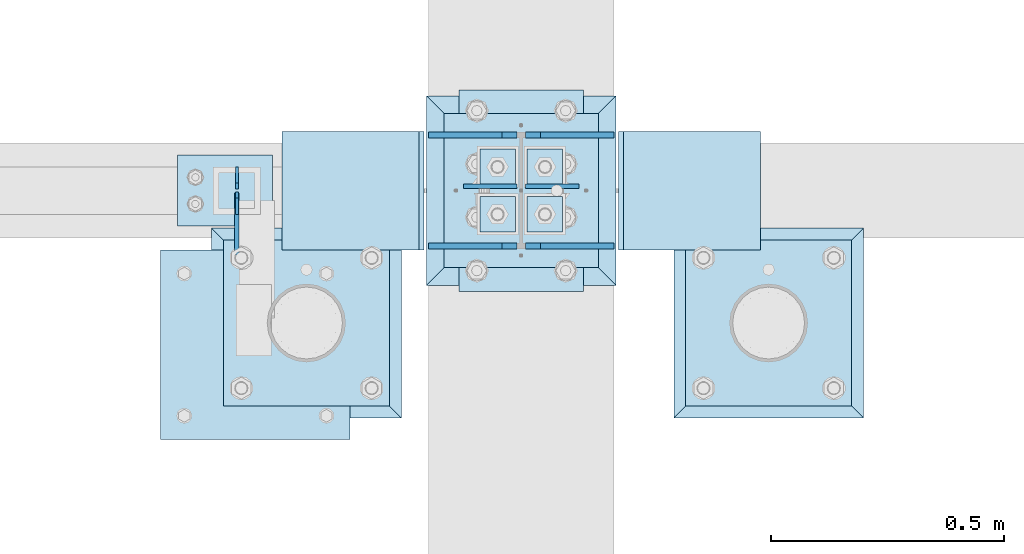
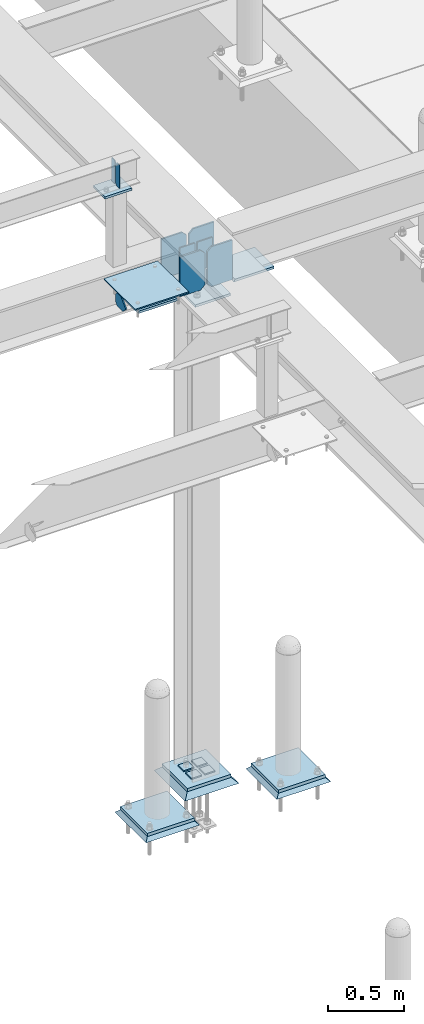
# One storey, part 3012 of 3843: 24 plates, 14 elements without a shape of their own.
"""IFC2X3 building model written with IfcOpenShell, lengths in millimetres."""

from ifc_helpers import new_model, si_unit, frame, origin_with_axes, place, context, subcontext, project, spatial, faceted_brep, material, type_object, element, aggregate, save


model = new_model("IFC2X3")

# Units and contexts
model_context = context("Model", 3, precision=1e-05, world=origin_with_axes())
body_context = subcontext(model_context, "Body", "Model", "MODEL_VIEW")
ifc_project = project(units=[si_unit("LENGTHUNIT", "METRE", prefix="MILLI"), si_unit("AREAUNIT", "SQUARE_METRE"), si_unit("VOLUMEUNIT", "CUBIC_METRE"), si_unit("MASSUNIT", "GRAM", prefix="KILO"), si_unit("TIMEUNIT", "SECOND"), si_unit("PLANEANGLEUNIT", "RADIAN"), si_unit("SOLIDANGLEUNIT", "STERADIAN"), si_unit("THERMODYNAMICTEMPERATUREUNIT", "DEGREE_CELSIUS"), si_unit("LUMINOUSINTENSITYUNIT", "LUMEN")], contexts=[model_context])

# Site, building, storey
site_placement = place(None, origin_with_axes())
site = spatial("IfcSite", under=ifc_project, at=site_placement, CompositionType="ELEMENT")
building_placement = place(site_placement, origin_with_axes())
building = spatial("IfcBuilding", under=site, at=building_placement, Name="Undefined", CompositionType="ELEMENT")
storey_placement = place(building_placement, origin_with_axes())
storey = spatial("IfcBuildingStorey", under=building, at=storey_placement, Name="Undefined", CompositionType="ELEMENT", Elevation=0.0)

# Assembly, plate
assembly_1_placement = place(storey_placement, origin_with_axes())
assembly_1 = element("IfcElementAssembly", 1, at=assembly_1_placement, inside=storey, Name="PIPE_BOLLARD", AssemblyPlace="NOTDEFINED", PredefinedType="RIGID_FRAME")
ifc_material_1 = material(Name="STEEL/A572-50")
plate_type_1 = type_object("IfcPlateType", PredefinedType="NOTDEFINED")
plate_1_placement = place(assembly_1_placement, frame((35937.8715698242, 14537.1457781578, 30518.1), z_axis=(0.0, 1.0, 0.0), x_axis=(1.0, 0.0, 0.0)))
plate_1 = element("IfcPlate", 2, at=plate_1_placement, type_object=plate_type_1, material=ifc_material_1, Name="PLATE", context=body_context, shape_type="Brep", body=[
    faceted_brep([(0.0, -12.6999999999971, 0.0), (0.0, -12.7000000000007, 355.600000000006), (0.0, 12.7000000000007, 355.600000000006), (0.0, 12.6999999999971, 0.0), (355.599999999999, -12.7000000000007, 355.600000000006), (355.599999999999, 12.7000000000007, 355.600000000006), (355.599999999999, -12.7000000000007, 0.0), (355.599999999999, 12.7000000000007, 0.0)], [[[0, 1, 2, 3]], [[1, 4, 5, 2]], [[4, 6, 7, 5]], [[6, 0, 3, 7]], [[5, 7, 3, 2]], [[6, 4, 1, 0]]]),
])
aggregate(assembly_1, [plate_1])

assembly_2_placement = place(storey_placement, origin_with_axes())
assembly_2 = element("IfcElementAssembly", 3, at=assembly_2_placement, inside=storey, Name="PIPE_BOLLARD", AssemblyPlace="NOTDEFINED", PredefinedType="RIGID_FRAME")
plate_2_placement = place(assembly_2_placement, frame((36928.4721557617, 14537.1457781578, 30518.1), z_axis=(0.0, 1.0, 0.0), x_axis=(1.0, 0.0, 0.0)))
plate_2 = element("IfcPlate", 4, at=plate_2_placement, type_object=plate_type_1, material=ifc_material_1, Name="PLATE", context=body_context, shape_type="Brep", body=[
    faceted_brep([(0.0, -12.6999999999971, 0.0), (0.0, -12.7000000000007, 355.600000000006), (0.0, 12.7000000000007, 355.600000000006), (0.0, 12.6999999999971, 0.0), (355.599999999999, -12.7000000000007, 355.600000000006), (355.599999999999, 12.7000000000007, 355.600000000006), (355.599999999999, -12.7000000000007, 0.0), (355.599999999999, 12.7000000000007, 0.0)], [[[0, 1, 2, 3]], [[1, 4, 5, 2]], [[4, 6, 7, 5]], [[6, 0, 3, 7]], [[5, 7, 3, 2]], [[6, 4, 1, 0]]]),
])
aggregate(assembly_2, [plate_2])

assembly_3_placement = place(storey_placement, origin_with_axes())
assembly_3 = element("IfcElementAssembly", 5, at=assembly_3_placement, inside=storey, Name="GROUT", AssemblyPlace="NOTDEFINED", PredefinedType="REINFORCEMENT_UNIT")
ifc_material_2 = material(Name="CONCRETE/Concrete_Undefined")
plate_type_2 = type_object("IfcPlateType", PredefinedType="NOTDEFINED")
plate_3_placement = place(assembly_3_placement, frame((35912.4715698242, 14511.7457781578, 30492.7), z_axis=(0.0, 1.0, 0.0), x_axis=(1.0, 0.0, 0.0)))
plate_3 = element("IfcPlate", 6, at=plate_3_placement, type_object=plate_type_2, material=ifc_material_2, Name="GROUT", context=body_context, shape_type="Brep", body=[
    faceted_brep([(25.4000000001906, -12.6999999998552, 380.999999999505), (0.0, 12.7000000000007, 406.399999999994), (0.0, 12.6999999999971, 0.0), (25.4000000001906, -12.6999999999898, 25.4000000004453), (380.999999999833, -12.6999999998588, 25.4000000004453), (406.400000000001, 12.7000000000007, 0.0), (406.400000000001, 12.7000000000007, 406.399999999994), (380.999999999833, -12.6999999999898, 380.999999999505)], [[[0, 1, 2, 3]], [[4, 5, 6, 7]], [[4, 7, 0, 3]], [[5, 4, 3, 2]], [[6, 5, 2, 1]], [[7, 6, 1, 0]]]),
])
aggregate(assembly_3, [plate_3])

assembly_4_placement = place(storey_placement, origin_with_axes())
assembly_4 = element("IfcElementAssembly", 7, at=assembly_4_placement, inside=storey, Name="GROUT", AssemblyPlace="NOTDEFINED", PredefinedType="REINFORCEMENT_UNIT")
plate_4_placement = place(assembly_4_placement, frame((36903.0721557617, 14511.7457781578, 30492.7), z_axis=(0.0, 1.0, 0.0), x_axis=(1.0, 0.0, 0.0)))
plate_4 = element("IfcPlate", 8, at=plate_4_placement, type_object=plate_type_2, material=ifc_material_2, Name="GROUT", context=body_context, shape_type="Brep", body=[
    faceted_brep([(25.4000000001906, -12.6999999998552, 380.999999999505), (0.0, 12.7000000000007, 406.399999999994), (0.0, 12.6999999999971, 0.0), (25.4000000001906, -12.6999999999898, 25.4000000004453), (380.999999999833, -12.6999999998588, 25.4000000004453), (406.400000000001, 12.7000000000007, 0.0), (406.400000000001, 12.7000000000007, 406.399999999994), (380.999999999833, -12.6999999999898, 380.999999999505)], [[[0, 1, 2, 3]], [[4, 5, 6, 7]], [[4, 7, 0, 3]], [[5, 4, 3, 2]], [[6, 5, 2, 1]], [[7, 6, 1, 0]]]),
])
aggregate(assembly_4, [plate_4])

# Assembly, plates
assembly_5_placement = place(storey_placement, origin_with_axes())
assembly_5 = element("IfcElementAssembly", 9, at=assembly_5_placement, inside=storey, Name="BEAM", AssemblyPlace="NOTDEFINED", PredefinedType="RIGID_FRAME")
plate_type_3 = type_object("IfcPlateType", PredefinedType="NOTDEFINED")
plate_5_placement = place(assembly_5_placement, frame((35966.4, 15049.5, 35615.5624969482), z_axis=(0.0, 0.0, -1.0), x_axis=(0.0, -1.0, 0.0)))
plate_5 = element("IfcPlate", 10, at=plate_5_placement, type_object=plate_type_3, material=ifc_material_1, Name="STIFFENER", context=body_context, shape_type="Brep", body=[
    faceted_brep([(0.0, -3.17499999999927, 0.0), (0.0, -3.17500000000291, 187.324999999997), (0.0, 3.17500000000291, 187.324999999997), (0.0, 3.17499999999927, 0.0), (34.9250001907349, -3.17500000000291, 187.324999999997), (34.9250001907349, 3.17500000000291, 187.324999999997), (47.625, -3.17500000000291, 174.625000190732), (47.625, 3.17500000000291, 174.625000190732), (47.625, -3.17499999999927, 12.6999998092651), (47.625, 3.17499999999927, 12.6999998092651), (34.9250001907349, -3.17499999999927, 0.0), (34.9250001907349, 3.17499999999927, 0.0)], [[[0, 1, 2, 3]], [[1, 4, 5, 2]], [[4, 6, 7, 5]], [[6, 8, 9, 7]], [[8, 10, 11, 9]], [[10, 0, 3, 11]], [[5, 7, 9, 11, 3, 2]], [[10, 8, 6, 4, 1, 0]]]),
])
plate_6_placement = place(assembly_5_placement, frame((35966.4, 14947.9, 35615.5624969482), z_axis=(0.0, 0.0, -1.0), x_axis=(0.0, 1.0, 0.0)))
plate_6 = element("IfcPlate", 11, at=plate_6_placement, type_object=plate_type_3, material=ifc_material_1, Name="STIFFENER", context=body_context, shape_type="Brep", body=[
    faceted_brep([(0.0, -3.17499999999927, 0.0), (0.0, -3.17500000000291, 187.324999999997), (0.0, 3.17500000000291, 187.324999999997), (0.0, 3.17499999999927, 0.0), (34.9250001907349, -3.17500000000291, 187.324999999997), (34.9250001907349, 3.17500000000291, 187.324999999997), (47.625, -3.17500000000291, 174.625000190732), (47.625, 3.17500000000291, 174.625000190732), (47.625, -3.17499999999927, 12.6999998092651), (47.625, 3.17499999999927, 12.6999998092651), (34.9250001907349, -3.17499999999927, 0.0), (34.9250001907349, 3.17499999999927, 0.0)], [[[0, 1, 2, 3]], [[1, 4, 5, 2]], [[4, 6, 7, 5]], [[6, 8, 9, 7]], [[8, 10, 11, 9]], [[10, 0, 3, 11]], [[5, 7, 9, 11, 3, 2]], [[10, 8, 6, 4, 1, 0]]]),
])
aggregate(assembly_5, [plate_5, plate_6])

assembly_6_placement = place(storey_placement, origin_with_axes())
assembly_6 = element("IfcElementAssembly", 12, at=assembly_6_placement, inside=storey, Name="BEAM", AssemblyPlace="NOTDEFINED", PredefinedType="RIGID_FRAME")
plate_type_4 = type_object("IfcPlateType", PredefinedType="NOTDEFINED")
plate_7_placement = place(assembly_6_placement, frame((36585.525, 15008.225, 34747.2), z_axis=(1.0, 0.0, 0.0), x_axis=(0.0, 0.0, -1.0)))
plate_7 = element("IfcPlate", 13, at=plate_7_placement, type_object=plate_type_4, material=ifc_material_1, Name="PLATE", context=body_context, shape_type="Brep", body=[
    faceted_brep([(0.0, -4.76249999999709, 0.0), (0.0, -4.76249999999709, 114.300003051758), (0.0, 4.76249999999709, 114.300003051758), (0.0, 4.76249999999709, 0.0), (228.600006103516, -4.76249999999709, 114.300003051758), (228.600006103516, 4.76249999999709, 114.300003051758), (228.600006103079, -4.7625000004482, 7.27595761418343e-12), (228.600006103079, 4.76249999954598, -7.27595761418343e-12)], [[[0, 1, 2, 3]], [[1, 4, 5, 2]], [[4, 6, 7, 5]], [[6, 0, 3, 7]], [[5, 7, 3, 2]], [[6, 4, 1, 0]]]),
])
plate_8_placement = place(assembly_6_placement, frame((36566.475, 15008.225, 34747.2), z_axis=(-1.0, 0.0, 0.0), x_axis=(0.0, 0.0, -1.0)))
plate_8 = element("IfcPlate", 14, at=plate_8_placement, type_object=plate_type_4, material=ifc_material_1, Name="PLATE", context=body_context, shape_type="Brep", body=[
    faceted_brep([(0.0, -4.76249999999709, 0.0), (0.0, -4.76249999999709, 114.300003051758), (0.0, 4.76249999999709, 114.300003051758), (0.0, 4.76249999999709, 0.0), (228.600006103516, -4.76249999999709, 114.300003051758), (228.600006103516, 4.76249999999709, 114.300003051758), (228.600006103079, -4.7625000004482, 7.27595761418343e-12), (228.600006103079, 4.76249999954598, -7.27595761418343e-12)], [[[0, 1, 2, 3]], [[1, 4, 5, 2]], [[4, 6, 7, 5]], [[6, 0, 3, 7]], [[5, 7, 3, 2]], [[6, 4, 1, 0]]]),
])

assembly_7_placement = place(storey_placement, origin_with_axes())
assembly_7 = element("IfcElementAssembly", 15, at=assembly_7_placement, inside=storey, Name="TEMPLATE", AssemblyPlace="NOTDEFINED", PredefinedType="RIGID_FRAME")
plate_type_5 = type_object("IfcPlateType", PredefinedType="NOTDEFINED")
plate_9_placement = place(assembly_7_placement, frame((36563.3, 14986.0, 30548.2625), z_axis=(-1.0, 0.0, 0.0), x_axis=(0.0, -1.0, 0.0)))
plate_9 = element("IfcPlate", 16, at=plate_9_placement, type_object=plate_type_5, material=ifc_material_1, Name="Washer Plate", context=body_context, shape_type="Brep", body=[
    faceted_brep([(0.0, -4.76249999999709, 0.0), (-3.49245965480804e-10, -4.76249999999709, 76.1999999999462), (-3.49245965480804e-10, 4.76249999999709, 76.1999999999462), (0.0, 4.76249999999709, 0.0), (76.1999893188477, -4.76249999999709, 76.1999969482422), (76.1999893188477, 4.76249999999709, 76.1999969482422), (76.2000000012922, -4.76250000000073, 7.27595761418343e-11), (76.2000000012922, 4.76250000000073, 7.27595761418343e-11)], [[[0, 1, 2, 3]], [[1, 4, 5, 2]], [[4, 6, 7, 5]], [[6, 0, 3, 7]], [[5, 7, 3, 2]], [[6, 4, 1, 0]]]),
])
plate_10_placement = place(assembly_7_placement, frame((36664.9, 14986.0, 30548.2625), z_axis=(-1.0, 0.0, 0.0), x_axis=(0.0, -1.0, 0.0)))
plate_10 = element("IfcPlate", 17, at=plate_10_placement, type_object=plate_type_5, material=ifc_material_1, Name="Washer Plate", context=body_context, shape_type="Brep", body=[
    faceted_brep([(0.0, -4.76249999999709, 0.0), (-3.49245965480804e-10, -4.76249999999709, 76.1999999999462), (-3.49245965480804e-10, 4.76249999999709, 76.1999999999462), (0.0, 4.76249999999709, 0.0), (76.1999893188477, -4.76249999999709, 76.1999969482422), (76.1999893188477, 4.76249999999709, 76.1999969482422), (76.2000000012922, -4.76250000000073, 7.27595761418343e-11), (76.2000000012922, 4.76250000000073, 7.27595761418343e-11)], [[[0, 1, 2, 3]], [[1, 4, 5, 2]], [[4, 6, 7, 5]], [[6, 0, 3, 7]], [[5, 7, 3, 2]], [[6, 4, 1, 0]]]),
])
plate_11_placement = place(assembly_7_placement, frame((36563.3, 15087.6, 30548.2625), z_axis=(-1.0, 0.0, 0.0), x_axis=(0.0, -1.0, 0.0)))
plate_11 = element("IfcPlate", 18, at=plate_11_placement, type_object=plate_type_5, material=ifc_material_1, Name="Washer Plate", context=body_context, shape_type="Brep", body=[
    faceted_brep([(0.0, -4.76249999999709, 0.0), (-3.49245965480804e-10, -4.76249999999709, 76.1999999999462), (-3.49245965480804e-10, 4.76249999999709, 76.1999999999462), (0.0, 4.76249999999709, 0.0), (76.1999893188477, -4.76249999999709, 76.1999969482422), (76.1999893188477, 4.76249999999709, 76.1999969482422), (76.2000000012922, -4.76250000000073, 7.27595761418343e-11), (76.2000000012922, 4.76250000000073, 7.27595761418343e-11)], [[[0, 1, 2, 3]], [[1, 4, 5, 2]], [[4, 6, 7, 5]], [[6, 0, 3, 7]], [[5, 7, 3, 2]], [[6, 4, 1, 0]]]),
])
plate_12_placement = place(assembly_7_placement, frame((36664.9, 15087.6, 30548.2625), z_axis=(-1.0, 0.0, 0.0), x_axis=(0.0, -1.0, 0.0)))
plate_12 = element("IfcPlate", 19, at=plate_12_placement, type_object=plate_type_5, material=ifc_material_1, Name="Washer Plate", context=body_context, shape_type="Brep", body=[
    faceted_brep([(0.0, -4.76249999999709, 0.0), (-3.49245965480804e-10, -4.76249999999709, 76.1999999999462), (-3.49245965480804e-10, 4.76249999999709, 76.1999999999462), (0.0, 4.76249999999709, 0.0), (76.1999893188477, -4.76249999999709, 76.1999969482422), (76.1999893188477, 4.76249999999709, 76.1999969482422), (76.2000000012922, -4.76250000000073, 7.27595761418343e-11), (76.2000000012922, 4.76250000000073, 7.27595761418343e-11)], [[[0, 1, 2, 3]], [[1, 4, 5, 2]], [[4, 6, 7, 5]], [[6, 0, 3, 7]], [[5, 7, 3, 2]], [[6, 4, 1, 0]]]),
])
aggregate(assembly_7, [plate_9, plate_10, plate_11, plate_12])

# Assembly, plate
assembly_8_placement = place(storey_placement, origin_with_axes())
assembly_8 = element("IfcElementAssembly", 20, at=assembly_8_placement, inside=storey, Name="BEAM", AssemblyPlace="NOTDEFINED", PredefinedType="RIGID_FRAME")
plate_type_6 = type_object("IfcPlateType", PredefinedType="NOTDEFINED")
plate_13_placement = place(assembly_8_placement, frame((36783.9633846577, 14871.7, 34448.75), z_axis=(1.0, 0.0, 0.0), x_axis=(0.0, 1.0, 0.0)))
plate_13 = element("IfcPlate", 21, at=plate_13_placement, type_object=plate_type_6, material=ifc_material_1, Name="PLATE", context=body_context, shape_type="Brep", body=[
    faceted_brep([(253.999999999998, 9.52500000019791, 10.9986594824586), (253.999999999998, -9.52500000000146, 0.0), (0.0, -9.52500000000146, 0.0), (0.0, 9.52500000000146, 10.9986594824586), (1.81898940354586e-12, -9.52500000000146, 304.800000000003), (253.999999999998, -9.52500000000146, 304.799999999996), (253.999999999998, 9.52500000000146, 304.799999999996), (1.81898940354586e-12, 9.52500000000146, 304.800000000003)], [[[0, 1, 2, 3]], [[4, 5, 6, 7]], [[7, 6, 0, 3]], [[4, 7, 3, 2]], [[5, 4, 2, 1]], [[6, 5, 1, 0]]]),
])
aggregate(assembly_8, [plate_13])

assembly_9_placement = place(storey_placement, origin_with_axes())
assembly_9 = element("IfcElementAssembly", 22, at=assembly_9_placement, inside=storey, Name="BEAM", AssemblyPlace="NOTDEFINED", PredefinedType="RIGID_FRAME")
plate_14_placement = place(assembly_9_placement, frame((36368.0366153423, 14871.7, 34448.75), z_axis=(-1.0, 0.0, 0.0), x_axis=(0.0, 1.0, 0.0)))
plate_14 = element("IfcPlate", 23, at=plate_14_placement, type_object=plate_type_6, material=ifc_material_1, Name="PLATE", context=body_context, shape_type="Brep", body=[
    faceted_brep([(253.999999999998, -9.52500000019791, 10.9986594824586), (0.0, -9.52500000000146, 10.9986594824586), (0.0, 9.52500000000146, 0.0), (253.999999999998, 9.52500000000146, 0.0), (1.81898940354586e-12, -9.52500000000146, 304.800000000003), (253.999999999998, -9.52500000000146, 304.799999999996), (253.999999999998, 9.52500000000146, 304.799999999996), (1.81898940354586e-12, 9.52500000000146, 304.800000000003)], [[[0, 1, 2, 3]], [[4, 5, 6, 7]], [[6, 5, 0, 3]], [[7, 6, 3, 2]], [[4, 7, 2, 1]], [[5, 4, 1, 0]]]),
])
aggregate(assembly_9, [plate_14])

assembly_10_placement = place(storey_placement, origin_with_axes())
assembly_10 = element("IfcElementAssembly", 24, at=assembly_10_placement, inside=storey, Name="PLATE", AssemblyPlace="NOTDEFINED", PredefinedType="RIGID_FRAME")
plate_type_7 = type_object("IfcPlateType", PredefinedType="NOTDEFINED")
plate_15_placement = place(assembly_10_placement, frame((35966.4, 14993.9375, 34475.7375), z_axis=(0.0, -1.0, 0.0), x_axis=(0.0, 0.0, 1.0)))
plate_15 = element("IfcPlate", 25, at=plate_15_placement, type_object=plate_type_7, material=ifc_material_1, Name="PLATE", context=body_context, shape_type="Brep", body=[
    faceted_brep([(0.0, -4.76249999999709, 19.0499992370605), (0.0, -4.76249999999709, 94.5650612206882), (0.0, 4.76249999999709, 94.5650612206882), (0.0, 4.76249999999709, 19.0499992370605), (38.5980122320107, -4.76249999999709, 133.163073452699), (38.5980122320107, 4.76249999999709, 133.163073452699), (128.400573442581, -4.76249999999709, 43.3605122421359), (128.400573442581, 4.76249999999709, 43.3605122421359), (85.0400612004451, -4.76249999999709, 0.0), (85.0400612004451, 4.76249999999709, 0.0), (19.0499992370605, -4.76249999999709, 0.0), (19.0499992370605, 4.76249999999709, 0.0)], [[[0, 1, 2, 3]], [[1, 4, 5, 2]], [[4, 6, 7, 5]], [[6, 8, 9, 7]], [[8, 10, 11, 9]], [[10, 0, 3, 11]], [[5, 7, 9, 11, 3, 2]], [[10, 8, 6, 4, 1, 0]]]),
])
aggregate(assembly_10, [plate_15])

assembly_11_placement = place(storey_placement, origin_with_axes())
assembly_11 = element("IfcElementAssembly", 26, at=assembly_11_placement, inside=storey, Name="PLATE", AssemblyPlace="NOTDEFINED", PredefinedType="RIGID_FRAME")
plate_type_8 = type_object("IfcPlateType", PredefinedType="NOTDEFINED")
plate_16_placement = place(assembly_11_placement, frame((35802.8875, 14871.7, 34805.9375), z_axis=(1.0, 0.0, 0.0), x_axis=(0.0, -1.0, 0.0)))
plate_16 = element("IfcPlate", 27, at=plate_16_placement, type_object=plate_type_8, material=ifc_material_1, Name="PLATE", context=body_context, shape_type="Brep", body=[
    faceted_brep([(0.0, -4.76249999999709, 0.0), (-7.27595761418343e-12, -4.76249999999709, 406.400000000009), (-7.27595761418343e-12, 4.76249999999709, 406.400000000009), (0.0, 4.76249999999709, 0.0), (406.399999999991, -4.76249999999709, 406.400000000009), (406.399999999991, 4.76249999999709, 406.400000000009), (406.399999999998, -4.76249999999709, 7.27595761418343e-12), (406.399999999998, 4.76249999999709, 7.27595761418343e-12)], [[[0, 1, 2, 3]], [[1, 4, 5, 2]], [[4, 6, 7, 5]], [[6, 0, 3, 7]], [[5, 7, 3, 2]], [[6, 4, 1, 0]]]),
])
aggregate(assembly_11, [plate_16])

assembly_12_placement = place(storey_placement, origin_with_axes())
assembly_12 = element("IfcElementAssembly", 28, at=assembly_12_placement, inside=storey, Name="POST", AssemblyPlace="NOTDEFINED", PredefinedType="RIGID_FRAME")
plate_type_9 = type_object("IfcPlateType", PredefinedType="NOTDEFINED")
plate_17_placement = place(assembly_12_placement, frame((36042.6, 15074.9, 35410.7749969482), z_axis=(-1.0, 0.0, 0.0), x_axis=(0.0, -1.0, 0.0)))
plate_17 = element("IfcPlate", 29, at=plate_17_placement, type_object=plate_type_9, material=ifc_material_1, Name="PLATE", context=body_context, shape_type="Brep", body=[
    faceted_brep([(0.0, -9.52500000000146, 0.0), (0.0, -9.52500000000146, 203.200000000004), (0.0, 9.52500000000146, 203.200000000004), (0.0, 9.52500000000146, 0.0), (152.400000000001, -9.52500000000146, 203.200000000004), (152.400000000001, 9.52500000000146, 203.200000000004), (152.400000000001, -9.52500000000146, 0.0), (152.400000000001, 9.52500000000146, 0.0)], [[[0, 1, 2, 3]], [[1, 4, 5, 2]], [[4, 6, 7, 5]], [[6, 0, 3, 7]], [[5, 7, 3, 2]], [[6, 4, 1, 0]]]),
])
aggregate(assembly_12, [plate_17])

# Assembly, plates
assembly_13_placement = place(storey_placement, origin_with_axes())
assembly_13 = element("IfcElementAssembly", 30, at=assembly_13_placement, inside=storey, Name="COLUMN", AssemblyPlace="NOTDEFINED", PredefinedType="RIGID_FRAME")
plate_type_10 = type_object("IfcPlateType", PredefinedType="NOTDEFINED")
plate_18_placement = place(assembly_13_placement, frame((36410.9, 15163.8, 30530.8), z_axis=(1.0, 0.0, 0.0), x_axis=(0.0, -1.0, 0.0)))
plate_18 = element("IfcPlate", 31, at=plate_18_placement, type_object=plate_type_10, material=ifc_material_1, Name="PLATE", context=body_context, shape_type="Brep", body=[
    faceted_brep([(0.0, -12.6999999999971, 0.0), (0.0, -12.6999999999825, 330.199999999997), (-1.45519152283669e-11, 12.699999999968, 330.199999999997), (0.0, 12.6999999999971, 0.0), (330.200012207031, -12.7000000000007, 330.200012207031), (330.200012207031, 12.7000000000007, 330.200012207031), (330.200012207031, -12.7000000000007, 0.0), (330.200012207031, 12.7000000000007, 0.0)], [[[0, 1, 2, 3]], [[1, 4, 5, 2]], [[4, 6, 7, 5]], [[6, 0, 3, 7]], [[5, 7, 3, 2]], [[6, 4, 1, 0]]]),
])
plate_type_11 = type_object("IfcPlateType", PredefinedType="NOTDEFINED")
plate_19_placement = place(assembly_13_placement, frame((36709.35, 14782.8, 34420.175), z_axis=(0.0, 1.0, 0.0), x_axis=(-1.0, 0.0, 0.0)))
plate_19 = element("IfcPlate", 32, at=plate_19_placement, type_object=plate_type_11, material=ifc_material_1, Name="PLATE", context=body_context, shape_type="Brep", body=[
    faceted_brep([(0.0, -9.52500000000146, 0.0), (0.0, -9.52500000000146, 431.799987792969), (0.0, 9.52500000000146, 431.799987792969), (0.0, 9.52500000000146, 0.0), (266.700012207031, -9.52500000000146, 431.799987792969), (266.700012207031, 9.52500000000146, 431.799987792969), (266.700012207031, -9.52500000000146, 0.0), (266.700012207031, 9.52500000000146, 0.0)], [[[0, 1, 2, 3]], [[1, 4, 5, 2]], [[4, 6, 7, 5]], [[6, 0, 3, 7]], [[5, 7, 3, 2]], [[6, 4, 1, 0]]]),
])
aggregate(assembly_13, [plate_19, plate_18])

# Plate
plate_type_12 = type_object("IfcPlateType", PredefinedType="NOTDEFINED")
plate_20_placement = place(assembly_6_placement, frame((36774.4375, 14879.6375, 34778.95), z_axis=(0.0, 0.0, -1.0), x_axis=(-1.0, 0.0, 0.0)))
plate_20 = element("IfcPlate", 33, at=plate_20_placement, type_object=plate_type_12, material=ifc_material_1, Name="PLATE", context=body_context, shape_type="Brep", body=[
    faceted_brep([(0.0, -6.3499999046162, 0.0), (0.0, -6.34999999999854, 317.5), (0.0, 6.34999999999854, 317.5), (7.27595761418343e-12, 6.3499999046162, 0.0), (157.162506103516, -6.35000000000036, 317.5), (157.162506103516, 6.35000000000036, 317.5), (188.912506103516, -6.35000000000036, 285.75), (188.912506103516, 6.35000000000036, 285.75), (188.912506103516, -6.35000000000036, 31.75), (188.912506103516, 6.35000000000036, 31.75), (157.162506103516, -6.35000000000036, 0.0), (157.162506103516, 6.35000000000036, 0.0)], [[[0, 1, 2, 3]], [[1, 4, 5, 2]], [[4, 6, 7, 5]], [[6, 8, 9, 7]], [[8, 10, 11, 9]], [[10, 0, 3, 11]], [[5, 7, 9, 11, 3, 2]], [[10, 8, 6, 4, 1, 0]]]),
])

plate_21_placement = place(assembly_6_placement, frame((36377.5625, 14879.6375, 34778.95), z_axis=(0.0, 0.0, -1.0), x_axis=(1.0, 0.0, 0.0)))
plate_21 = element("IfcPlate", 34, at=plate_21_placement, type_object=plate_type_12, material=ifc_material_1, Name="PLATE", context=body_context, shape_type="Brep", body=[
    faceted_brep([(0.0, -6.3499999046162, 0.0), (0.0, -6.34999999999854, 317.5), (0.0, 6.34999999999854, 317.5), (7.27595761418343e-12, 6.3499999046162, 0.0), (157.162506103516, -6.35000000000036, 317.5), (157.162506103516, 6.35000000000036, 317.5), (188.912506103516, -6.35000000000036, 285.75), (188.912506103516, 6.35000000000036, 285.75), (188.912506103516, -6.35000000000036, 31.75), (188.912506103516, 6.35000000000036, 31.75), (157.162506103516, -6.35000000000036, 0.0), (157.162506103516, 6.35000000000036, 0.0)], [[[0, 1, 2, 3]], [[1, 4, 5, 2]], [[4, 6, 7, 5]], [[6, 8, 9, 7]], [[8, 10, 11, 9]], [[10, 0, 3, 11]], [[5, 7, 9, 11, 3, 2]], [[10, 8, 6, 4, 1, 0]]]),
])

plate_22_placement = place(assembly_6_placement, frame((36774.4375, 15117.7625, 34778.95), z_axis=(0.0, 0.0, -1.0), x_axis=(-1.0, 0.0, 0.0)))
plate_22 = element("IfcPlate", 35, at=plate_22_placement, type_object=plate_type_12, material=ifc_material_1, Name="PLATE", context=body_context, shape_type="Brep", body=[
    faceted_brep([(0.0, -6.3499999046162, 0.0), (0.0, -6.34999999999854, 317.5), (0.0, 6.34999999999854, 317.5), (7.27595761418343e-12, 6.3499999046162, 0.0), (157.162506103516, -6.35000000000036, 317.5), (157.162506103516, 6.35000000000036, 317.5), (188.912506103516, -6.35000000000036, 285.75), (188.912506103516, 6.35000000000036, 285.75), (188.912506103516, -6.35000000000036, 31.75), (188.912506103516, 6.35000000000036, 31.75), (157.162506103516, -6.35000000000036, 0.0), (157.162506103516, 6.35000000000036, 0.0)], [[[0, 1, 2, 3]], [[1, 4, 5, 2]], [[4, 6, 7, 5]], [[6, 8, 9, 7]], [[8, 10, 11, 9]], [[10, 0, 3, 11]], [[5, 7, 9, 11, 3, 2]], [[10, 8, 6, 4, 1, 0]]]),
])

plate_23_placement = place(assembly_6_placement, frame((36377.5625, 15117.7625, 34778.95), z_axis=(0.0, 0.0, -1.0), x_axis=(1.0, 0.0, 0.0)))
plate_23 = element("IfcPlate", 36, at=plate_23_placement, type_object=plate_type_12, material=ifc_material_1, Name="PLATE", context=body_context, shape_type="Brep", body=[
    faceted_brep([(0.0, -6.3499999046162, 0.0), (0.0, -6.34999999999854, 317.5), (0.0, 6.34999999999854, 317.5), (7.27595761418343e-12, 6.3499999046162, 0.0), (157.162506103516, -6.35000000000036, 317.5), (157.162506103516, 6.35000000000036, 317.5), (188.912506103516, -6.35000000000036, 285.75), (188.912506103516, 6.35000000000036, 285.75), (188.912506103516, -6.35000000000036, 31.75), (188.912506103516, 6.35000000000036, 31.75), (157.162506103516, -6.35000000000036, 0.0), (157.162506103516, 6.35000000000036, 0.0)], [[[0, 1, 2, 3]], [[1, 4, 5, 2]], [[4, 6, 7, 5]], [[6, 8, 9, 7]], [[8, 10, 11, 9]], [[10, 0, 3, 11]], [[5, 7, 9, 11, 3, 2]], [[10, 8, 6, 4, 1, 0]]]),
])

aggregate(assembly_6, [plate_7, plate_8, plate_20, plate_21, plate_22, plate_23])

# Assembly, plate
assembly_14_placement = place(storey_placement, origin_with_axes())
assembly_14 = element("IfcElementAssembly", 37, at=assembly_14_placement, inside=storey, Name="GROUT", AssemblyPlace="NOTDEFINED", PredefinedType="REINFORCEMENT_UNIT")
plate_type_13 = type_object("IfcPlateType", PredefinedType="NOTDEFINED")
plate_24_placement = place(assembly_14_placement, frame((36372.8, 15201.9, 30499.05), z_axis=(1.0, 0.0, 0.0), x_axis=(0.0, -1.0, 0.0)))
plate_24 = element("IfcPlate", 38, at=plate_24_placement, type_object=plate_type_13, material=ifc_material_2, Name="GROUT", context=body_context, shape_type="Brep", body=[
    faceted_brep([(38.1000000006916, -19.0499999997883, 368.299999999334), (0.0, 19.0499999999993, 406.399993896484), (0.0, 19.0500000000029, 0.0), (38.1000000006916, -19.0499999999811, 38.1000000006607), (368.299999999343, -19.049999999821, 38.1000000006607), (406.399993896484, 19.0499999999993, 0.0), (406.399993896484, 19.0499999999993, 406.399993896484), (368.299999999343, -19.0499999999811, 368.299999999334)], [[[0, 1, 2, 3]], [[4, 5, 6, 7]], [[4, 7, 0, 3]], [[5, 4, 3, 2]], [[6, 5, 2, 1]], [[7, 6, 1, 0]]]),
])
aggregate(assembly_14, [plate_24])

save(model, "model.ifc")
